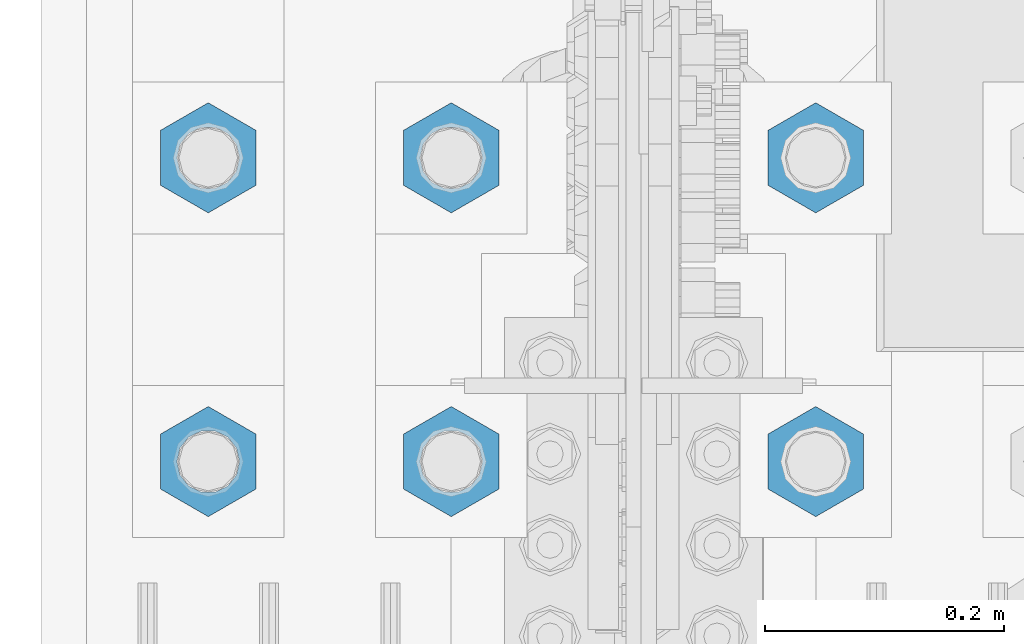
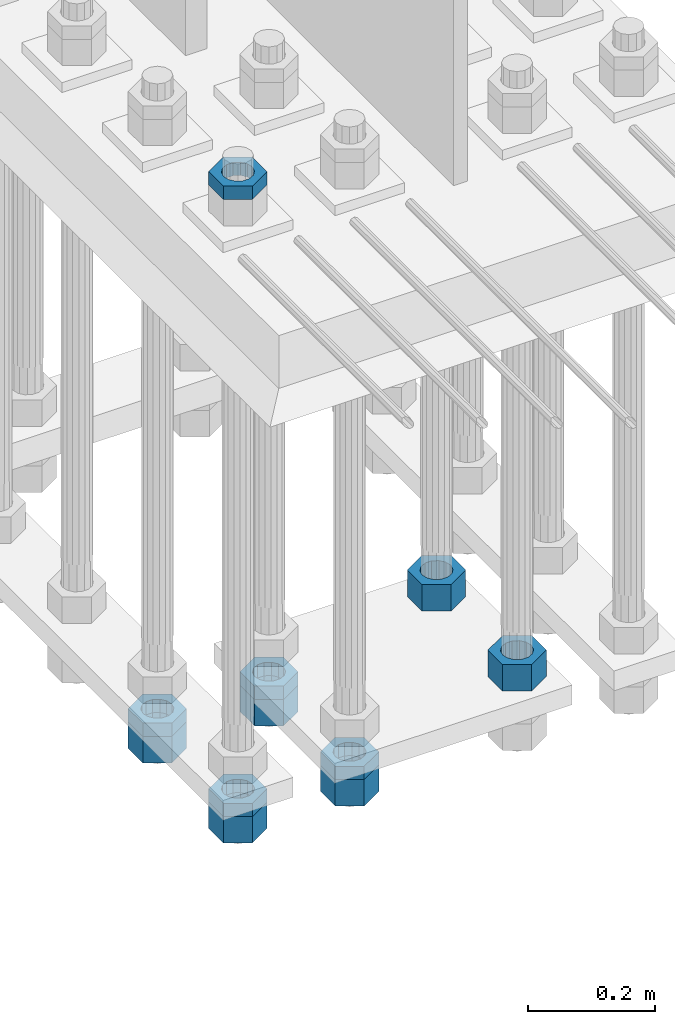
# One storey, part 2211 of 3843: 11 beams, 1 element without a shape of its own.
"""IFC2X3 building model written with IfcOpenShell, lengths in millimetres."""

from ifc_helpers import new_model, si_unit, frame, origin_with_axes, place, context, subcontext, project, spatial, faceted_brep, material, type_object, element, aggregate, save


model = new_model("IFC2X3")

# Units and contexts
model_context = context("Model", 3, precision=1e-05, world=origin_with_axes())
body_context = subcontext(model_context, "Body", "Model", "MODEL_VIEW")
ifc_project = project(units=[si_unit("LENGTHUNIT", "METRE", prefix="MILLI"), si_unit("AREAUNIT", "SQUARE_METRE"), si_unit("VOLUMEUNIT", "CUBIC_METRE"), si_unit("MASSUNIT", "GRAM", prefix="KILO"), si_unit("TIMEUNIT", "SECOND"), si_unit("PLANEANGLEUNIT", "RADIAN"), si_unit("SOLIDANGLEUNIT", "STERADIAN"), si_unit("THERMODYNAMICTEMPERATUREUNIT", "DEGREE_CELSIUS"), si_unit("LUMINOUSINTENSITYUNIT", "LUMEN")], contexts=[model_context])

# Site, building, storey
site_placement = place(None, origin_with_axes())
site = spatial("IfcSite", under=ifc_project, at=site_placement, CompositionType="ELEMENT")
building_placement = place(site_placement, origin_with_axes())
building = spatial("IfcBuilding", under=site, at=building_placement, Name="Undefined", CompositionType="ELEMENT")
storey_placement = place(building_placement, origin_with_axes())
storey = spatial("IfcBuildingStorey", under=building, at=storey_placement, Name="Undefined", CompositionType="ELEMENT", Elevation=0.0)

# Assembly, beams
assembly_placement = place(storey_placement, origin_with_axes())
assembly = element("IfcElementAssembly", 1, at=assembly_placement, inside=storey, Name="TEMPLATE", AssemblyPlace="NOTDEFINED", PredefinedType="RIGID_FRAME")
ifc_material = material(Name="STEEL/A572-50")
beam_type_1 = type_object("IfcBeamType", Name="2_HALF_NUT", PredefinedType="NOTDEFINED")
beam_1_placement = place(assembly_placement, frame((36220.4, 58280.3, 30257.75), z_axis=(-1.0, 0.0, 0.0), x_axis=(0.0, 0.0, -1.0)))
beam_1 = element("IfcBeam", 2, at=beam_1_placement, type_object=beam_type_1, material=ifc_material, Name="NUT", ObjectType="2_HALF_NUT", context=body_context, shape_type="Brep", body=[
    faceted_brep([(0.0, -46.0369987487793, 0.0), (0.0, -23.0184993743896, -39.869213104248), (25.4000000000015, -23.0184993743896, -39.869213104248), (25.4000000000015, -46.0369987487793, 0.0), (0.0, 23.0184993743896, -39.869213104248), (25.4000000000015, 23.0184993743896, -39.869213104248), (0.0, 46.0369987487793, 0.0), (25.4000000000015, 46.0369987487793, 0.0), (0.0, 23.0184993743896, 39.869213104248), (25.4000000000015, 23.0184993743896, 39.869213104248), (0.0, -23.0184993743896, 39.869213104248), (25.4000000000015, -23.0184993743896, 39.869213104248), (0.0, 0.0, 26.1940002441406), (0.0, 11.3650617044477, 23.5999013092805), (25.4000000000015, 11.3650617044477, 23.5999013092805), (25.4000000000015, 0.0, 26.1940002441406), (0.0, 20.4791109456419, 16.3316083006721), (25.4000000000015, 20.4791109456419, 16.3316083006721), (0.0, 25.5370200498292, 5.82867859874386), (25.4000000000015, 25.5370200498292, 5.82867859874386), (0.0, 25.5370200498292, -5.82867859874386), (25.4000000000015, 25.5370200498292, -5.82867859874386), (0.0, 20.4791109456419, -16.3316083006721), (25.4000000000015, 20.4791109456419, -16.3316083006721), (0.0, 11.3650617044477, -23.5999013092805), (25.4000000000015, 11.3650617044477, -23.5999013092805), (0.0, 0.0, -26.1940002441406), (25.4000000000015, 0.0, -26.1940002441406), (0.0, -11.3650617044477, -23.5999013092805), (25.4000000000015, -11.3650617044477, -23.5999013092805), (0.0, -20.4791109456419, -16.3316083006721), (25.4000000000015, -20.4791109456419, -16.3316083006721), (0.0, -25.5370200498292, -5.82867859874386), (25.4000000000015, -25.5370200498292, -5.82867859874386), (0.0, -25.5370200498292, 5.82867859874386), (25.4000000000015, -25.5370200498292, 5.82867859874386), (0.0, -20.4791109456419, 16.3316083006721), (25.4000000000015, -20.4791109456419, 16.3316083006721), (0.0, -11.3650617044477, 23.5999013092805), (25.4000000000015, -11.3650617044477, 23.5999013092805)], [[[0, 1, 2, 3]], [[1, 4, 5, 2]], [[4, 6, 7, 5]], [[6, 8, 9, 7]], [[8, 10, 11, 9]], [[10, 0, 3, 11]], [[12, 13, 14, 15]], [[13, 16, 17, 14]], [[16, 18, 19, 17]], [[18, 20, 21, 19]], [[20, 22, 23, 21]], [[22, 24, 25, 23]], [[24, 26, 27, 25]], [[26, 28, 29, 27]], [[28, 30, 31, 29]], [[30, 32, 33, 31]], [[32, 34, 35, 33]], [[34, 36, 37, 35]], [[36, 38, 39, 37]], [[38, 12, 15, 39]], [[5, 7, 9, 11, 3, 2], [17, 19, 21, 23, 25, 27, 29, 31, 33, 35, 37, 39, 15, 14]], [[10, 8, 6, 4, 1, 0], [38, 36, 34, 32, 30, 28, 26, 24, 22, 20, 18, 16, 13, 12]]]),
])
beam_2_placement = place(assembly_placement, frame((36423.6, 58280.3, 29070.3), z_axis=(-1.0, 0.0, 0.0), x_axis=(0.0, 0.0, -1.0)))
beam_2 = element("IfcBeam", 3, at=beam_2_placement, type_object=beam_type_1, material=ifc_material, Name="NUT", ObjectType="2_HALF_NUT", context=body_context, shape_type="Brep", body=[
    faceted_brep([(0.0, -46.0369987487793, 0.0), (0.0, -23.0184993743896, -39.869213104248), (25.4000000000015, -23.0184993743896, -39.869213104248), (25.4000000000015, -46.0369987487793, 0.0), (0.0, 23.0184993743896, -39.869213104248), (25.4000000000015, 23.0184993743896, -39.869213104248), (0.0, 46.0369987487793, 0.0), (25.4000000000015, 46.0369987487793, 0.0), (0.0, 23.0184993743896, 39.869213104248), (25.4000000000015, 23.0184993743896, 39.869213104248), (0.0, -23.0184993743896, 39.869213104248), (25.4000000000015, -23.0184993743896, 39.869213104248), (0.0, 0.0, 26.1940002441406), (0.0, 11.3650617044477, 23.5999013092805), (25.4000000000015, 11.3650617044477, 23.5999013092805), (25.4000000000015, 0.0, 26.1940002441406), (0.0, 20.4791109456419, 16.3316083006721), (25.4000000000015, 20.4791109456419, 16.3316083006721), (0.0, 25.5370200498292, 5.82867859874386), (25.4000000000015, 25.5370200498292, 5.82867859874386), (0.0, 25.5370200498292, -5.82867859874386), (25.4000000000015, 25.5370200498292, -5.82867859874386), (0.0, 20.4791109456419, -16.3316083006721), (25.4000000000015, 20.4791109456419, -16.3316083006721), (0.0, 11.3650617044477, -23.5999013092805), (25.4000000000015, 11.3650617044477, -23.5999013092805), (0.0, 0.0, -26.1940002441406), (25.4000000000015, 0.0, -26.1940002441406), (0.0, -11.3650617044477, -23.5999013092805), (25.4000000000015, -11.3650617044477, -23.5999013092805), (0.0, -20.4791109456419, -16.3316083006721), (25.4000000000015, -20.4791109456419, -16.3316083006721), (0.0, -25.5370200498292, -5.82867859874386), (25.4000000000015, -25.5370200498292, -5.82867859874386), (0.0, -25.5370200498292, 5.82867859874386), (25.4000000000015, -25.5370200498292, 5.82867859874386), (0.0, -20.4791109456419, 16.3316083006721), (25.4000000000015, -20.4791109456419, 16.3316083006721), (0.0, -11.3650617044477, 23.5999013092805), (25.4000000000015, -11.3650617044477, 23.5999013092805)], [[[0, 1, 2, 3]], [[1, 4, 5, 2]], [[4, 6, 7, 5]], [[6, 8, 9, 7]], [[8, 10, 11, 9]], [[10, 0, 3, 11]], [[12, 13, 14, 15]], [[13, 16, 17, 14]], [[16, 18, 19, 17]], [[18, 20, 21, 19]], [[20, 22, 23, 21]], [[22, 24, 25, 23]], [[24, 26, 27, 25]], [[26, 28, 29, 27]], [[28, 30, 31, 29]], [[30, 32, 33, 31]], [[32, 34, 35, 33]], [[34, 36, 37, 35]], [[36, 38, 39, 37]], [[38, 12, 15, 39]], [[5, 7, 9, 11, 3, 2], [17, 19, 21, 23, 25, 27, 29, 31, 33, 35, 37, 39, 15, 14]], [[10, 8, 6, 4, 1, 0], [38, 36, 34, 32, 30, 28, 26, 24, 22, 20, 18, 16, 13, 12]]]),
])
beam_3_placement = place(assembly_placement, frame((36423.6, 58534.3, 29070.3), z_axis=(-1.0, 0.0, 0.0), x_axis=(0.0, 0.0, -1.0)))
beam_3 = element("IfcBeam", 4, at=beam_3_placement, type_object=beam_type_1, material=ifc_material, Name="NUT", ObjectType="2_HALF_NUT", context=body_context, shape_type="Brep", body=[
    faceted_brep([(0.0, -46.0369987487793, 0.0), (0.0, -23.0184993743896, -39.869213104248), (25.4000000000015, -23.0184993743896, -39.869213104248), (25.4000000000015, -46.0369987487793, 0.0), (0.0, 23.0184993743896, -39.869213104248), (25.4000000000015, 23.0184993743896, -39.869213104248), (0.0, 46.0369987487793, 0.0), (25.4000000000015, 46.0369987487793, 0.0), (0.0, 23.0184993743896, 39.869213104248), (25.4000000000015, 23.0184993743896, 39.869213104248), (0.0, -23.0184993743896, 39.869213104248), (25.4000000000015, -23.0184993743896, 39.869213104248), (0.0, 0.0, 26.1940002441406), (0.0, 11.3650617044477, 23.5999013092805), (25.4000000000015, 11.3650617044477, 23.5999013092805), (25.4000000000015, 0.0, 26.1940002441406), (0.0, 20.4791109456419, 16.3316083006721), (25.4000000000015, 20.4791109456419, 16.3316083006721), (0.0, 25.5370200498292, 5.82867859874386), (25.4000000000015, 25.5370200498292, 5.82867859874386), (0.0, 25.5370200498292, -5.82867859874386), (25.4000000000015, 25.5370200498292, -5.82867859874386), (0.0, 20.4791109456419, -16.3316083006721), (25.4000000000015, 20.4791109456419, -16.3316083006721), (0.0, 11.3650617044477, -23.5999013092805), (25.4000000000015, 11.3650617044477, -23.5999013092805), (0.0, 0.0, -26.1940002441406), (25.4000000000015, 0.0, -26.1940002441406), (0.0, -11.3650617044477, -23.5999013092805), (25.4000000000015, -11.3650617044477, -23.5999013092805), (0.0, -20.4791109456419, -16.3316083006721), (25.4000000000015, -20.4791109456419, -16.3316083006721), (0.0, -25.5370200498292, -5.82867859874386), (25.4000000000015, -25.5370200498292, -5.82867859874386), (0.0, -25.5370200498292, 5.82867859874386), (25.4000000000015, -25.5370200498292, 5.82867859874386), (0.0, -20.4791109456419, 16.3316083006721), (25.4000000000015, -20.4791109456419, 16.3316083006721), (0.0, -11.3650617044477, 23.5999013092805), (25.4000000000015, -11.3650617044477, 23.5999013092805)], [[[0, 1, 2, 3]], [[1, 4, 5, 2]], [[4, 6, 7, 5]], [[6, 8, 9, 7]], [[8, 10, 11, 9]], [[10, 0, 3, 11]], [[12, 13, 14, 15]], [[13, 16, 17, 14]], [[16, 18, 19, 17]], [[18, 20, 21, 19]], [[20, 22, 23, 21]], [[22, 24, 25, 23]], [[24, 26, 27, 25]], [[26, 28, 29, 27]], [[28, 30, 31, 29]], [[30, 32, 33, 31]], [[32, 34, 35, 33]], [[34, 36, 37, 35]], [[36, 38, 39, 37]], [[38, 12, 15, 39]], [[5, 7, 9, 11, 3, 2], [17, 19, 21, 23, 25, 27, 29, 31, 33, 35, 37, 39, 15, 14]], [[10, 8, 6, 4, 1, 0], [38, 36, 34, 32, 30, 28, 26, 24, 22, 20, 18, 16, 13, 12]]]),
])
beam_4_placement = place(assembly_placement, frame((36220.4, 58534.3, 29070.3), z_axis=(-1.0, 0.0, 0.0), x_axis=(0.0, 0.0, -1.0)))
beam_4 = element("IfcBeam", 5, at=beam_4_placement, type_object=beam_type_1, material=ifc_material, Name="NUT", ObjectType="2_HALF_NUT", context=body_context, shape_type="Brep", body=[
    faceted_brep([(0.0, -46.0369987487793, 0.0), (0.0, -23.0184993743896, -39.869213104248), (25.4000000000015, -23.0184993743896, -39.869213104248), (25.4000000000015, -46.0369987487793, 0.0), (0.0, 23.0184993743896, -39.869213104248), (25.4000000000015, 23.0184993743896, -39.869213104248), (0.0, 46.0369987487793, 0.0), (25.4000000000015, 46.0369987487793, 0.0), (0.0, 23.0184993743896, 39.869213104248), (25.4000000000015, 23.0184993743896, 39.869213104248), (0.0, -23.0184993743896, 39.869213104248), (25.4000000000015, -23.0184993743896, 39.869213104248), (0.0, 0.0, 26.1940002441406), (0.0, 11.3650617044477, 23.5999013092805), (25.4000000000015, 11.3650617044477, 23.5999013092805), (25.4000000000015, 0.0, 26.1940002441406), (0.0, 20.4791109456419, 16.3316083006721), (25.4000000000015, 20.4791109456419, 16.3316083006721), (0.0, 25.5370200498292, 5.82867859874386), (25.4000000000015, 25.5370200498292, 5.82867859874386), (0.0, 25.5370200498292, -5.82867859874386), (25.4000000000015, 25.5370200498292, -5.82867859874386), (0.0, 20.4791109456419, -16.3316083006721), (25.4000000000015, 20.4791109456419, -16.3316083006721), (0.0, 11.3650617044477, -23.5999013092805), (25.4000000000015, 11.3650617044477, -23.5999013092805), (0.0, 0.0, -26.1940002441406), (25.4000000000015, 0.0, -26.1940002441406), (0.0, -11.3650617044477, -23.5999013092805), (25.4000000000015, -11.3650617044477, -23.5999013092805), (0.0, -20.4791109456419, -16.3316083006721), (25.4000000000015, -20.4791109456419, -16.3316083006721), (0.0, -25.5370200498292, -5.82867859874386), (25.4000000000015, -25.5370200498292, -5.82867859874386), (0.0, -25.5370200498292, 5.82867859874386), (25.4000000000015, -25.5370200498292, 5.82867859874386), (0.0, -20.4791109456419, 16.3316083006721), (25.4000000000015, -20.4791109456419, 16.3316083006721), (0.0, -11.3650617044477, 23.5999013092805), (25.4000000000015, -11.3650617044477, 23.5999013092805)], [[[0, 1, 2, 3]], [[1, 4, 5, 2]], [[4, 6, 7, 5]], [[6, 8, 9, 7]], [[8, 10, 11, 9]], [[10, 0, 3, 11]], [[12, 13, 14, 15]], [[13, 16, 17, 14]], [[16, 18, 19, 17]], [[18, 20, 21, 19]], [[20, 22, 23, 21]], [[22, 24, 25, 23]], [[24, 26, 27, 25]], [[26, 28, 29, 27]], [[28, 30, 31, 29]], [[30, 32, 33, 31]], [[32, 34, 35, 33]], [[34, 36, 37, 35]], [[36, 38, 39, 37]], [[38, 12, 15, 39]], [[5, 7, 9, 11, 3, 2], [17, 19, 21, 23, 25, 27, 29, 31, 33, 35, 37, 39, 15, 14]], [[10, 8, 6, 4, 1, 0], [38, 36, 34, 32, 30, 28, 26, 24, 22, 20, 18, 16, 13, 12]]]),
])
beam_5_placement = place(assembly_placement, frame((36220.4, 58280.3, 29070.3), z_axis=(-1.0, 0.0, 0.0), x_axis=(0.0, 0.0, -1.0)))
beam_5 = element("IfcBeam", 6, at=beam_5_placement, type_object=beam_type_1, material=ifc_material, Name="NUT", ObjectType="2_HALF_NUT", context=body_context, shape_type="Brep", body=[
    faceted_brep([(0.0, -46.0369987487793, 0.0), (0.0, -23.0184993743896, -39.869213104248), (25.4000000000015, -23.0184993743896, -39.869213104248), (25.4000000000015, -46.0369987487793, 0.0), (0.0, 23.0184993743896, -39.869213104248), (25.4000000000015, 23.0184993743896, -39.869213104248), (0.0, 46.0369987487793, 0.0), (25.4000000000015, 46.0369987487793, 0.0), (0.0, 23.0184993743896, 39.869213104248), (25.4000000000015, 23.0184993743896, 39.869213104248), (0.0, -23.0184993743896, 39.869213104248), (25.4000000000015, -23.0184993743896, 39.869213104248), (0.0, 0.0, 26.1940002441406), (0.0, 11.3650617044477, 23.5999013092805), (25.4000000000015, 11.3650617044477, 23.5999013092805), (25.4000000000015, 0.0, 26.1940002441406), (0.0, 20.4791109456419, 16.3316083006721), (25.4000000000015, 20.4791109456419, 16.3316083006721), (0.0, 25.5370200498292, 5.82867859874386), (25.4000000000015, 25.5370200498292, 5.82867859874386), (0.0, 25.5370200498292, -5.82867859874386), (25.4000000000015, 25.5370200498292, -5.82867859874386), (0.0, 20.4791109456419, -16.3316083006721), (25.4000000000015, 20.4791109456419, -16.3316083006721), (0.0, 11.3650617044477, -23.5999013092805), (25.4000000000015, 11.3650617044477, -23.5999013092805), (0.0, 0.0, -26.1940002441406), (25.4000000000015, 0.0, -26.1940002441406), (0.0, -11.3650617044477, -23.5999013092805), (25.4000000000015, -11.3650617044477, -23.5999013092805), (0.0, -20.4791109456419, -16.3316083006721), (25.4000000000015, -20.4791109456419, -16.3316083006721), (0.0, -25.5370200498292, -5.82867859874386), (25.4000000000015, -25.5370200498292, -5.82867859874386), (0.0, -25.5370200498292, 5.82867859874386), (25.4000000000015, -25.5370200498292, 5.82867859874386), (0.0, -20.4791109456419, 16.3316083006721), (25.4000000000015, -20.4791109456419, 16.3316083006721), (0.0, -11.3650617044477, 23.5999013092805), (25.4000000000015, -11.3650617044477, 23.5999013092805)], [[[0, 1, 2, 3]], [[1, 4, 5, 2]], [[4, 6, 7, 5]], [[6, 8, 9, 7]], [[8, 10, 11, 9]], [[10, 0, 3, 11]], [[12, 13, 14, 15]], [[13, 16, 17, 14]], [[16, 18, 19, 17]], [[18, 20, 21, 19]], [[20, 22, 23, 21]], [[22, 24, 25, 23]], [[24, 26, 27, 25]], [[26, 28, 29, 27]], [[28, 30, 31, 29]], [[30, 32, 33, 31]], [[32, 34, 35, 33]], [[34, 36, 37, 35]], [[36, 38, 39, 37]], [[38, 12, 15, 39]], [[5, 7, 9, 11, 3, 2], [17, 19, 21, 23, 25, 27, 29, 31, 33, 35, 37, 39, 15, 14]], [[10, 8, 6, 4, 1, 0], [38, 36, 34, 32, 30, 28, 26, 24, 22, 20, 18, 16, 13, 12]]]),
])
beam_type_2 = type_object("IfcBeamType", Name="2_HEAVY_HEX_NUT", PredefinedType="NOTDEFINED")
beam_6_placement = place(assembly_placement, frame((36728.4, 58534.3, 29159.2), z_axis=(-1.0, 0.0, 0.0), x_axis=(0.0, 0.0, -1.0)))
beam_6 = element("IfcBeam", 7, at=beam_6_placement, type_object=beam_type_2, material=ifc_material, Name="NUT", ObjectType="2_HEAVY_HEX_NUT", context=body_context, shape_type="Brep", body=[
    faceted_brep([(0.0, -46.0369987487793, 0.0), (0.0, -23.0184993743896, -39.869213104248), (50.7999999999993, -23.0184993743896, -39.869213104248), (50.7999999999993, -46.0369987487793, 0.0), (0.0, 23.0184993743896, -39.869213104248), (50.7999999999993, 23.0184993743896, -39.869213104248), (0.0, 46.0369987487793, 0.0), (50.7999999999993, 46.0369987487793, 0.0), (0.0, 23.0184993743896, 39.869213104248), (50.7999999999993, 23.0184993743896, 39.869213104248), (0.0, -23.0184993743896, 39.869213104248), (50.7999999999993, -23.0184993743896, 39.869213104248), (0.0, 0.0, 26.1940002441406), (0.0, 11.3650617044477, 23.5999013092805), (50.7999999999993, 11.3650617044477, 23.5999013092805), (50.7999999999993, 0.0, 26.1940002441406), (0.0, 20.4791109456419, 16.3316083006721), (50.7999999999993, 20.4791109456419, 16.3316083006721), (0.0, 25.5370200498292, 5.82867859874386), (50.7999999999993, 25.5370200498292, 5.82867859874386), (0.0, 25.5370200498292, -5.82867859874386), (50.7999999999993, 25.5370200498292, -5.82867859874386), (0.0, 20.4791109456419, -16.3316083006721), (50.7999999999993, 20.4791109456419, -16.3316083006721), (0.0, 11.3650617044477, -23.5999013092805), (50.7999999999993, 11.3650617044477, -23.5999013092805), (0.0, 0.0, -26.1940002441406), (50.7999999999993, 0.0, -26.1940002441406), (0.0, -11.3650617044477, -23.5999013092805), (50.7999999999993, -11.3650617044477, -23.5999013092805), (0.0, -20.4791109456419, -16.3316083006721), (50.7999999999993, -20.4791109456419, -16.3316083006721), (0.0, -25.5370200498292, -5.82867859874386), (50.7999999999993, -25.5370200498292, -5.82867859874386), (0.0, -25.5370200498292, 5.82867859874386), (50.7999999999993, -25.5370200498292, 5.82867859874386), (0.0, -20.4791109456419, 16.3316083006721), (50.7999999999993, -20.4791109456419, 16.3316083006721), (0.0, -11.3650617044477, 23.5999013092805), (50.7999999999993, -11.3650617044477, 23.5999013092805)], [[[0, 1, 2, 3]], [[1, 4, 5, 2]], [[4, 6, 7, 5]], [[6, 8, 9, 7]], [[8, 10, 11, 9]], [[10, 0, 3, 11]], [[12, 13, 14, 15]], [[13, 16, 17, 14]], [[16, 18, 19, 17]], [[18, 20, 21, 19]], [[20, 22, 23, 21]], [[22, 24, 25, 23]], [[24, 26, 27, 25]], [[26, 28, 29, 27]], [[28, 30, 31, 29]], [[30, 32, 33, 31]], [[32, 34, 35, 33]], [[34, 36, 37, 35]], [[36, 38, 39, 37]], [[38, 12, 15, 39]], [[5, 7, 9, 11, 3, 2], [17, 19, 21, 23, 25, 27, 29, 31, 33, 35, 37, 39, 15, 14]], [[10, 8, 6, 4, 1, 0], [38, 36, 34, 32, 30, 28, 26, 24, 22, 20, 18, 16, 13, 12]]]),
])
beam_7_placement = place(assembly_placement, frame((36728.4, 58280.3, 29159.2), z_axis=(-1.0, 0.0, 0.0), x_axis=(0.0, 0.0, -1.0)))
beam_7 = element("IfcBeam", 8, at=beam_7_placement, type_object=beam_type_2, material=ifc_material, Name="NUT", ObjectType="2_HEAVY_HEX_NUT", context=body_context, shape_type="Brep", body=[
    faceted_brep([(0.0, -46.0369987487793, 0.0), (0.0, -23.0184993743896, -39.869213104248), (50.7999999999993, -23.0184993743896, -39.869213104248), (50.7999999999993, -46.0369987487793, 0.0), (0.0, 23.0184993743896, -39.869213104248), (50.7999999999993, 23.0184993743896, -39.869213104248), (0.0, 46.0369987487793, 0.0), (50.7999999999993, 46.0369987487793, 0.0), (0.0, 23.0184993743896, 39.869213104248), (50.7999999999993, 23.0184993743896, 39.869213104248), (0.0, -23.0184993743896, 39.869213104248), (50.7999999999993, -23.0184993743896, 39.869213104248), (0.0, 0.0, 26.1940002441406), (0.0, 11.3650617044477, 23.5999013092805), (50.7999999999993, 11.3650617044477, 23.5999013092805), (50.7999999999993, 0.0, 26.1940002441406), (0.0, 20.4791109456419, 16.3316083006721), (50.7999999999993, 20.4791109456419, 16.3316083006721), (0.0, 25.5370200498292, 5.82867859874386), (50.7999999999993, 25.5370200498292, 5.82867859874386), (0.0, 25.5370200498292, -5.82867859874386), (50.7999999999993, 25.5370200498292, -5.82867859874386), (0.0, 20.4791109456419, -16.3316083006721), (50.7999999999993, 20.4791109456419, -16.3316083006721), (0.0, 11.3650617044477, -23.5999013092805), (50.7999999999993, 11.3650617044477, -23.5999013092805), (0.0, 0.0, -26.1940002441406), (50.7999999999993, 0.0, -26.1940002441406), (0.0, -11.3650617044477, -23.5999013092805), (50.7999999999993, -11.3650617044477, -23.5999013092805), (0.0, -20.4791109456419, -16.3316083006721), (50.7999999999993, -20.4791109456419, -16.3316083006721), (0.0, -25.5370200498292, -5.82867859874386), (50.7999999999993, -25.5370200498292, -5.82867859874386), (0.0, -25.5370200498292, 5.82867859874386), (50.7999999999993, -25.5370200498292, 5.82867859874386), (0.0, -20.4791109456419, 16.3316083006721), (50.7999999999993, -20.4791109456419, 16.3316083006721), (0.0, -11.3650617044477, 23.5999013092805), (50.7999999999993, -11.3650617044477, 23.5999013092805)], [[[0, 1, 2, 3]], [[1, 4, 5, 2]], [[4, 6, 7, 5]], [[6, 8, 9, 7]], [[8, 10, 11, 9]], [[10, 0, 3, 11]], [[12, 13, 14, 15]], [[13, 16, 17, 14]], [[16, 18, 19, 17]], [[18, 20, 21, 19]], [[20, 22, 23, 21]], [[22, 24, 25, 23]], [[24, 26, 27, 25]], [[26, 28, 29, 27]], [[28, 30, 31, 29]], [[30, 32, 33, 31]], [[32, 34, 35, 33]], [[34, 36, 37, 35]], [[36, 38, 39, 37]], [[38, 12, 15, 39]], [[5, 7, 9, 11, 3, 2], [17, 19, 21, 23, 25, 27, 29, 31, 33, 35, 37, 39, 15, 14]], [[10, 8, 6, 4, 1, 0], [38, 36, 34, 32, 30, 28, 26, 24, 22, 20, 18, 16, 13, 12]]]),
])
beam_8_placement = place(assembly_placement, frame((36423.6, 58280.3, 29044.9), z_axis=(-1.0, 0.0, 0.0), x_axis=(0.0, 0.0, -1.0)))
beam_8 = element("IfcBeam", 9, at=beam_8_placement, type_object=beam_type_2, material=ifc_material, Name="NUT", ObjectType="2_HEAVY_HEX_NUT", context=body_context, shape_type="Brep", body=[
    faceted_brep([(0.0, -46.0369987487793, 0.0), (0.0, -23.0184993743896, -39.869213104248), (50.7999999999993, -23.0184993743896, -39.869213104248), (50.7999999999993, -46.0369987487793, 0.0), (0.0, 23.0184993743896, -39.869213104248), (50.7999999999993, 23.0184993743896, -39.869213104248), (0.0, 46.0369987487793, 0.0), (50.7999999999993, 46.0369987487793, 0.0), (0.0, 23.0184993743896, 39.869213104248), (50.7999999999993, 23.0184993743896, 39.869213104248), (0.0, -23.0184993743896, 39.869213104248), (50.7999999999993, -23.0184993743896, 39.869213104248), (0.0, 0.0, 26.1940002441406), (0.0, 11.3650617044477, 23.5999013092805), (50.7999999999993, 11.3650617044477, 23.5999013092805), (50.7999999999993, 0.0, 26.1940002441406), (0.0, 20.4791109456419, 16.3316083006721), (50.7999999999993, 20.4791109456419, 16.3316083006721), (0.0, 25.5370200498292, 5.82867859874386), (50.7999999999993, 25.5370200498292, 5.82867859874386), (0.0, 25.5370200498292, -5.82867859874386), (50.7999999999993, 25.5370200498292, -5.82867859874386), (0.0, 20.4791109456419, -16.3316083006721), (50.7999999999993, 20.4791109456419, -16.3316083006721), (0.0, 11.3650617044477, -23.5999013092805), (50.7999999999993, 11.3650617044477, -23.5999013092805), (0.0, 0.0, -26.1940002441406), (50.7999999999993, 0.0, -26.1940002441406), (0.0, -11.3650617044477, -23.5999013092805), (50.7999999999993, -11.3650617044477, -23.5999013092805), (0.0, -20.4791109456419, -16.3316083006721), (50.7999999999993, -20.4791109456419, -16.3316083006721), (0.0, -25.5370200498292, -5.82867859874386), (50.7999999999993, -25.5370200498292, -5.82867859874386), (0.0, -25.5370200498292, 5.82867859874386), (50.7999999999993, -25.5370200498292, 5.82867859874386), (0.0, -20.4791109456419, 16.3316083006721), (50.7999999999993, -20.4791109456419, 16.3316083006721), (0.0, -11.3650617044477, 23.5999013092805), (50.7999999999993, -11.3650617044477, 23.5999013092805)], [[[0, 1, 2, 3]], [[1, 4, 5, 2]], [[4, 6, 7, 5]], [[6, 8, 9, 7]], [[8, 10, 11, 9]], [[10, 0, 3, 11]], [[12, 13, 14, 15]], [[13, 16, 17, 14]], [[16, 18, 19, 17]], [[18, 20, 21, 19]], [[20, 22, 23, 21]], [[22, 24, 25, 23]], [[24, 26, 27, 25]], [[26, 28, 29, 27]], [[28, 30, 31, 29]], [[30, 32, 33, 31]], [[32, 34, 35, 33]], [[34, 36, 37, 35]], [[36, 38, 39, 37]], [[38, 12, 15, 39]], [[5, 7, 9, 11, 3, 2], [17, 19, 21, 23, 25, 27, 29, 31, 33, 35, 37, 39, 15, 14]], [[10, 8, 6, 4, 1, 0], [38, 36, 34, 32, 30, 28, 26, 24, 22, 20, 18, 16, 13, 12]]]),
])
beam_9_placement = place(assembly_placement, frame((36423.6, 58534.3, 29044.9), z_axis=(-1.0, 0.0, 0.0), x_axis=(0.0, 0.0, -1.0)))
beam_9 = element("IfcBeam", 10, at=beam_9_placement, type_object=beam_type_2, material=ifc_material, Name="NUT", ObjectType="2_HEAVY_HEX_NUT", context=body_context, shape_type="Brep", body=[
    faceted_brep([(0.0, -46.0369987487793, 0.0), (0.0, -23.0184993743896, -39.869213104248), (50.7999999999993, -23.0184993743896, -39.869213104248), (50.7999999999993, -46.0369987487793, 0.0), (0.0, 23.0184993743896, -39.869213104248), (50.7999999999993, 23.0184993743896, -39.869213104248), (0.0, 46.0369987487793, 0.0), (50.7999999999993, 46.0369987487793, 0.0), (0.0, 23.0184993743896, 39.869213104248), (50.7999999999993, 23.0184993743896, 39.869213104248), (0.0, -23.0184993743896, 39.869213104248), (50.7999999999993, -23.0184993743896, 39.869213104248), (0.0, 0.0, 26.1940002441406), (0.0, 11.3650617044477, 23.5999013092805), (50.7999999999993, 11.3650617044477, 23.5999013092805), (50.7999999999993, 0.0, 26.1940002441406), (0.0, 20.4791109456419, 16.3316083006721), (50.7999999999993, 20.4791109456419, 16.3316083006721), (0.0, 25.5370200498292, 5.82867859874386), (50.7999999999993, 25.5370200498292, 5.82867859874386), (0.0, 25.5370200498292, -5.82867859874386), (50.7999999999993, 25.5370200498292, -5.82867859874386), (0.0, 20.4791109456419, -16.3316083006721), (50.7999999999993, 20.4791109456419, -16.3316083006721), (0.0, 11.3650617044477, -23.5999013092805), (50.7999999999993, 11.3650617044477, -23.5999013092805), (0.0, 0.0, -26.1940002441406), (50.7999999999993, 0.0, -26.1940002441406), (0.0, -11.3650617044477, -23.5999013092805), (50.7999999999993, -11.3650617044477, -23.5999013092805), (0.0, -20.4791109456419, -16.3316083006721), (50.7999999999993, -20.4791109456419, -16.3316083006721), (0.0, -25.5370200498292, -5.82867859874386), (50.7999999999993, -25.5370200498292, -5.82867859874386), (0.0, -25.5370200498292, 5.82867859874386), (50.7999999999993, -25.5370200498292, 5.82867859874386), (0.0, -20.4791109456419, 16.3316083006721), (50.7999999999993, -20.4791109456419, 16.3316083006721), (0.0, -11.3650617044477, 23.5999013092805), (50.7999999999993, -11.3650617044477, 23.5999013092805)], [[[0, 1, 2, 3]], [[1, 4, 5, 2]], [[4, 6, 7, 5]], [[6, 8, 9, 7]], [[8, 10, 11, 9]], [[10, 0, 3, 11]], [[12, 13, 14, 15]], [[13, 16, 17, 14]], [[16, 18, 19, 17]], [[18, 20, 21, 19]], [[20, 22, 23, 21]], [[22, 24, 25, 23]], [[24, 26, 27, 25]], [[26, 28, 29, 27]], [[28, 30, 31, 29]], [[30, 32, 33, 31]], [[32, 34, 35, 33]], [[34, 36, 37, 35]], [[36, 38, 39, 37]], [[38, 12, 15, 39]], [[5, 7, 9, 11, 3, 2], [17, 19, 21, 23, 25, 27, 29, 31, 33, 35, 37, 39, 15, 14]], [[10, 8, 6, 4, 1, 0], [38, 36, 34, 32, 30, 28, 26, 24, 22, 20, 18, 16, 13, 12]]]),
])
beam_10_placement = place(assembly_placement, frame((36220.4, 58534.3, 29044.9), z_axis=(-1.0, 0.0, 0.0), x_axis=(0.0, 0.0, -1.0)))
beam_10 = element("IfcBeam", 11, at=beam_10_placement, type_object=beam_type_2, material=ifc_material, Name="NUT", ObjectType="2_HEAVY_HEX_NUT", context=body_context, shape_type="Brep", body=[
    faceted_brep([(0.0, -46.0369987487793, 0.0), (0.0, -23.0184993743896, -39.869213104248), (50.7999999999993, -23.0184993743896, -39.869213104248), (50.7999999999993, -46.0369987487793, 0.0), (0.0, 23.0184993743896, -39.869213104248), (50.7999999999993, 23.0184993743896, -39.869213104248), (0.0, 46.0369987487793, 0.0), (50.7999999999993, 46.0369987487793, 0.0), (0.0, 23.0184993743896, 39.869213104248), (50.7999999999993, 23.0184993743896, 39.869213104248), (0.0, -23.0184993743896, 39.869213104248), (50.7999999999993, -23.0184993743896, 39.869213104248), (0.0, 0.0, 26.1940002441406), (0.0, 11.3650617044477, 23.5999013092805), (50.7999999999993, 11.3650617044477, 23.5999013092805), (50.7999999999993, 0.0, 26.1940002441406), (0.0, 20.4791109456419, 16.3316083006721), (50.7999999999993, 20.4791109456419, 16.3316083006721), (0.0, 25.5370200498292, 5.82867859874386), (50.7999999999993, 25.5370200498292, 5.82867859874386), (0.0, 25.5370200498292, -5.82867859874386), (50.7999999999993, 25.5370200498292, -5.82867859874386), (0.0, 20.4791109456419, -16.3316083006721), (50.7999999999993, 20.4791109456419, -16.3316083006721), (0.0, 11.3650617044477, -23.5999013092805), (50.7999999999993, 11.3650617044477, -23.5999013092805), (0.0, 0.0, -26.1940002441406), (50.7999999999993, 0.0, -26.1940002441406), (0.0, -11.3650617044477, -23.5999013092805), (50.7999999999993, -11.3650617044477, -23.5999013092805), (0.0, -20.4791109456419, -16.3316083006721), (50.7999999999993, -20.4791109456419, -16.3316083006721), (0.0, -25.5370200498292, -5.82867859874386), (50.7999999999993, -25.5370200498292, -5.82867859874386), (0.0, -25.5370200498292, 5.82867859874386), (50.7999999999993, -25.5370200498292, 5.82867859874386), (0.0, -20.4791109456419, 16.3316083006721), (50.7999999999993, -20.4791109456419, 16.3316083006721), (0.0, -11.3650617044477, 23.5999013092805), (50.7999999999993, -11.3650617044477, 23.5999013092805)], [[[0, 1, 2, 3]], [[1, 4, 5, 2]], [[4, 6, 7, 5]], [[6, 8, 9, 7]], [[8, 10, 11, 9]], [[10, 0, 3, 11]], [[12, 13, 14, 15]], [[13, 16, 17, 14]], [[16, 18, 19, 17]], [[18, 20, 21, 19]], [[20, 22, 23, 21]], [[22, 24, 25, 23]], [[24, 26, 27, 25]], [[26, 28, 29, 27]], [[28, 30, 31, 29]], [[30, 32, 33, 31]], [[32, 34, 35, 33]], [[34, 36, 37, 35]], [[36, 38, 39, 37]], [[38, 12, 15, 39]], [[5, 7, 9, 11, 3, 2], [17, 19, 21, 23, 25, 27, 29, 31, 33, 35, 37, 39, 15, 14]], [[10, 8, 6, 4, 1, 0], [38, 36, 34, 32, 30, 28, 26, 24, 22, 20, 18, 16, 13, 12]]]),
])
beam_11_placement = place(assembly_placement, frame((36220.4, 58280.3, 29044.9), z_axis=(-1.0, 0.0, 0.0), x_axis=(0.0, 0.0, -1.0)))
beam_11 = element("IfcBeam", 12, at=beam_11_placement, type_object=beam_type_2, material=ifc_material, Name="NUT", ObjectType="2_HEAVY_HEX_NUT", context=body_context, shape_type="Brep", body=[
    faceted_brep([(0.0, -46.0369987487793, 0.0), (0.0, -23.0184993743896, -39.869213104248), (50.7999999999993, -23.0184993743896, -39.869213104248), (50.7999999999993, -46.0369987487793, 0.0), (0.0, 23.0184993743896, -39.869213104248), (50.7999999999993, 23.0184993743896, -39.869213104248), (0.0, 46.0369987487793, 0.0), (50.7999999999993, 46.0369987487793, 0.0), (0.0, 23.0184993743896, 39.869213104248), (50.7999999999993, 23.0184993743896, 39.869213104248), (0.0, -23.0184993743896, 39.869213104248), (50.7999999999993, -23.0184993743896, 39.869213104248), (0.0, 0.0, 26.1940002441406), (0.0, 11.3650617044477, 23.5999013092805), (50.7999999999993, 11.3650617044477, 23.5999013092805), (50.7999999999993, 0.0, 26.1940002441406), (0.0, 20.4791109456419, 16.3316083006721), (50.7999999999993, 20.4791109456419, 16.3316083006721), (0.0, 25.5370200498292, 5.82867859874386), (50.7999999999993, 25.5370200498292, 5.82867859874386), (0.0, 25.5370200498292, -5.82867859874386), (50.7999999999993, 25.5370200498292, -5.82867859874386), (0.0, 20.4791109456419, -16.3316083006721), (50.7999999999993, 20.4791109456419, -16.3316083006721), (0.0, 11.3650617044477, -23.5999013092805), (50.7999999999993, 11.3650617044477, -23.5999013092805), (0.0, 0.0, -26.1940002441406), (50.7999999999993, 0.0, -26.1940002441406), (0.0, -11.3650617044477, -23.5999013092805), (50.7999999999993, -11.3650617044477, -23.5999013092805), (0.0, -20.4791109456419, -16.3316083006721), (50.7999999999993, -20.4791109456419, -16.3316083006721), (0.0, -25.5370200498292, -5.82867859874386), (50.7999999999993, -25.5370200498292, -5.82867859874386), (0.0, -25.5370200498292, 5.82867859874386), (50.7999999999993, -25.5370200498292, 5.82867859874386), (0.0, -20.4791109456419, 16.3316083006721), (50.7999999999993, -20.4791109456419, 16.3316083006721), (0.0, -11.3650617044477, 23.5999013092805), (50.7999999999993, -11.3650617044477, 23.5999013092805)], [[[0, 1, 2, 3]], [[1, 4, 5, 2]], [[4, 6, 7, 5]], [[6, 8, 9, 7]], [[8, 10, 11, 9]], [[10, 0, 3, 11]], [[12, 13, 14, 15]], [[13, 16, 17, 14]], [[16, 18, 19, 17]], [[18, 20, 21, 19]], [[20, 22, 23, 21]], [[22, 24, 25, 23]], [[24, 26, 27, 25]], [[26, 28, 29, 27]], [[28, 30, 31, 29]], [[30, 32, 33, 31]], [[32, 34, 35, 33]], [[34, 36, 37, 35]], [[36, 38, 39, 37]], [[38, 12, 15, 39]], [[5, 7, 9, 11, 3, 2], [17, 19, 21, 23, 25, 27, 29, 31, 33, 35, 37, 39, 15, 14]], [[10, 8, 6, 4, 1, 0], [38, 36, 34, 32, 30, 28, 26, 24, 22, 20, 18, 16, 13, 12]]]),
])
aggregate(assembly, [beam_6, beam_7, beam_1, beam_8, beam_2, beam_9, beam_3, beam_10, beam_11, beam_4, beam_5])

save(model, "model.ifc")
